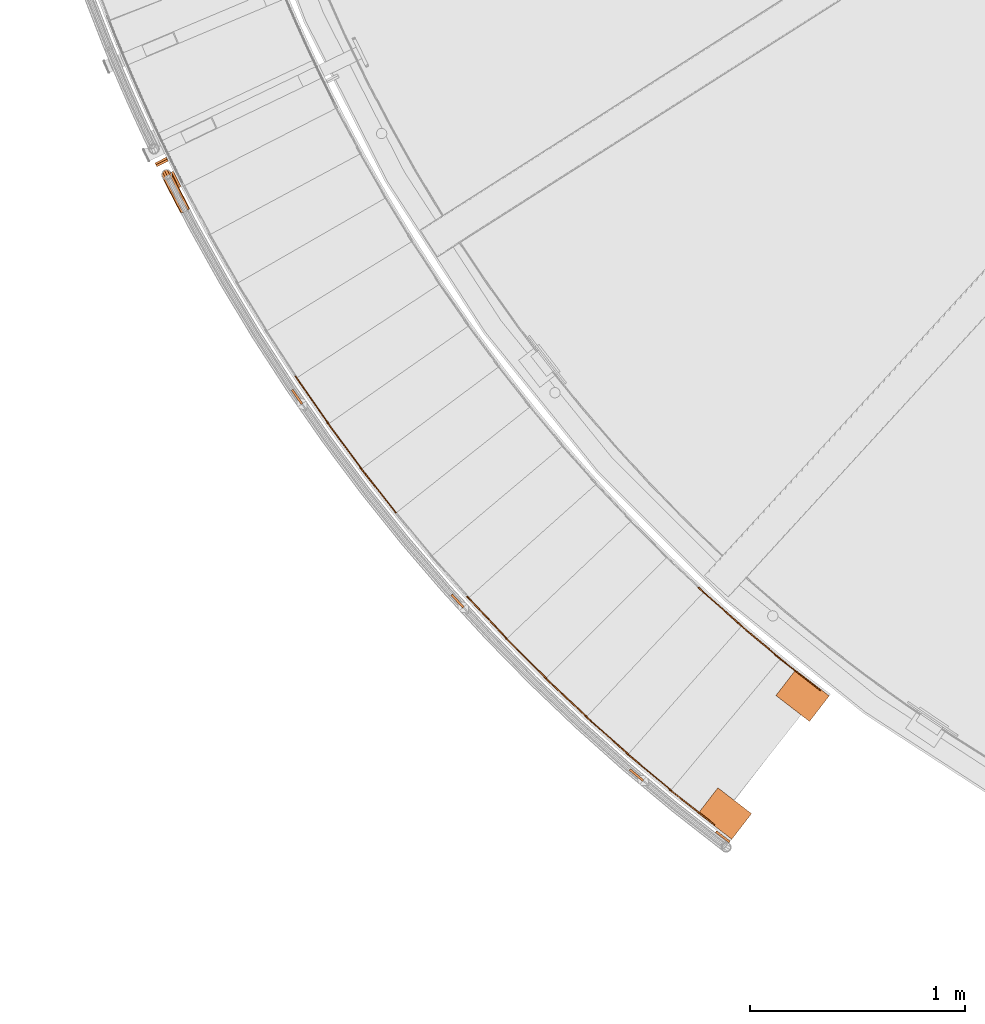
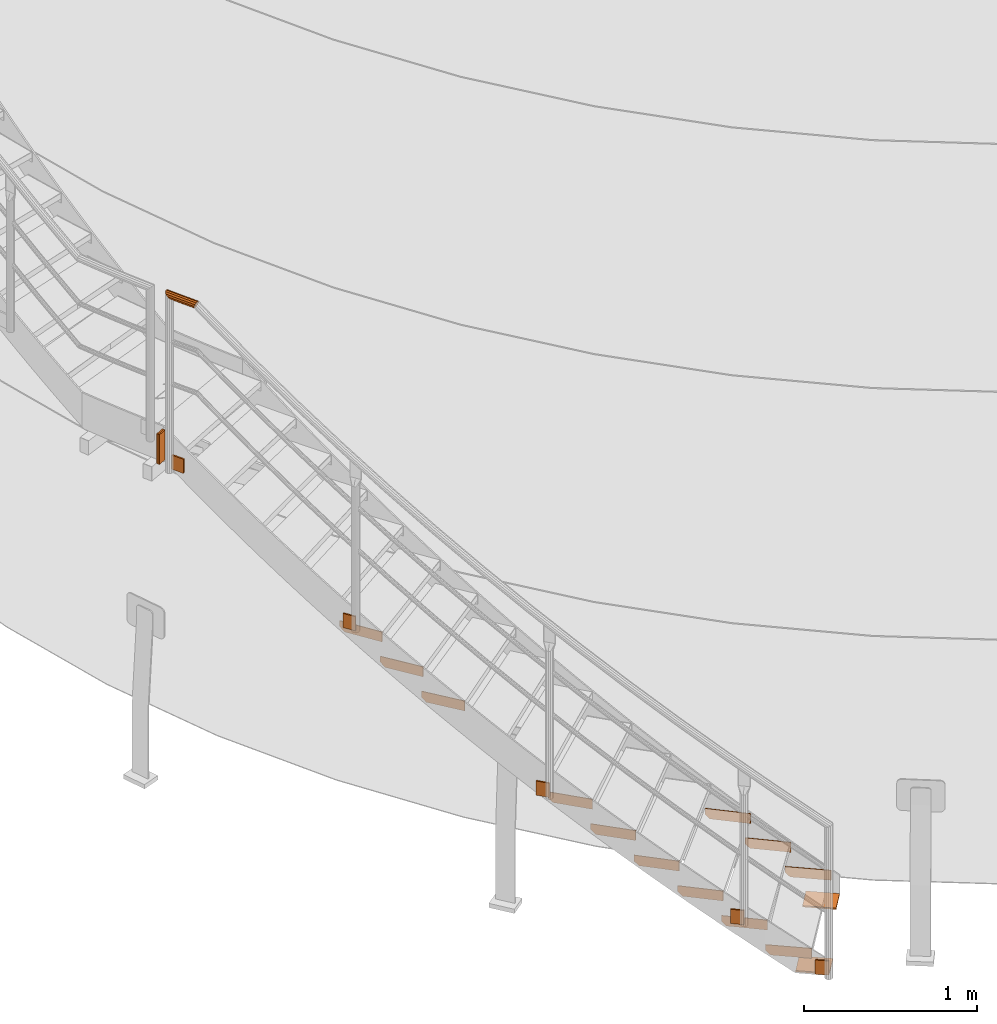
# One storey, part 44 of 126: 22 proxies.
"""IFC2X3 building model written with IfcOpenShell, lengths in millimetres."""

from ifc_helpers import new_model, si_unit, origin, origin_with_axes, place, context, project, spatial, faceted_brep, material, element, save


model = new_model("IFC2X3")

# Units and contexts
context_of_model_1 = context(None, 3, precision=0.1, world=origin())
context_of_model_2 = context(None, 3, precision=0.1, world=origin())
ifc_project = project(units=[si_unit("LENGTHUNIT", "METRE", prefix="MILLI"), si_unit("AREAUNIT", "SQUARE_METRE", prefix="CENTI"), si_unit("VOLUMEUNIT", "CUBIC_METRE", prefix="CENTI"), si_unit("MASSUNIT", "GRAM", prefix="KILO")], contexts=[context_of_model_1, context_of_model_2])

# Site, building, storey
site_placement = place(None, origin_with_axes())
site = spatial("IfcSite", under=ifc_project, at=site_placement, CompositionType="ELEMENT")
building_placement = place(site_placement, origin_with_axes())
building = spatial("IfcBuilding", under=site, at=building_placement, CompositionType="ELEMENT")
storey_placement = place(building_placement, origin_with_axes())
storey = spatial("IfcBuildingStorey", under=building, at=storey_placement, CompositionType="ELEMENT")

# Proxies
ifc_material = material(Name="S235JRG2")
proxy_1_placement = place(storey_placement, origin_with_axes())
element("IfcBuildingElementProxy", 1, at=proxy_1_placement, inside=storey, material=ifc_material, context=context_of_model_2, shape_type="Brep", body=[
    faceted_brep([(3107.5909, 1651.4086, 103.21), (3110.6795, 1655.3406, 103.21), (3110.6795, 1655.3406, 173.21), (3107.5909, 1651.4086, 173.21), (2895.2639, 1818.1936, 173.21), (2898.3525, 1822.1256, 173.21), (2898.3525, 1822.1256, 133.21), (2895.2639, 1818.1936, 133.21), (2918.8558, 1799.662, 103.21), (2921.9444, 1803.5939, 103.21)], [[[0, 1, 2, 3]], [[4, 5, 6, 7]], [[0, 8, 9, 1]], [[1, 9, 6, 5, 2]], [[2, 5, 4, 3]], [[0, 3, 4, 7, 8]], [[6, 9, 8, 7]]]),
])
proxy_2_placement = place(storey_placement, origin_with_axes())
element("IfcBuildingElementProxy", 2, at=proxy_2_placement, inside=storey, material=ifc_material, context=context_of_model_2, shape_type="Brep", body=[
    faceted_brep([(2616.5018, 1026.2235, 103.21), (2619.5904, 1030.1555, 103.21), (2619.5904, 1030.1555, 173.21), (2616.5018, 1026.2235, 173.21), (2404.1747, 1193.0085, 173.21), (2407.2634, 1196.9405, 173.21), (2407.2634, 1196.9405, 133.21), (2404.1747, 1193.0085, 133.21), (2427.7666, 1174.4768, 103.21), (2430.8552, 1178.4088, 103.21)], [[[0, 1, 2, 3]], [[4, 5, 6, 7]], [[0, 8, 9, 1]], [[1, 9, 6, 5, 2]], [[2, 5, 4, 3]], [[0, 3, 4, 7, 8]], [[6, 9, 8, 7]]]),
])
proxy_3_placement = place(storey_placement, origin_with_axes())
element("IfcBuildingElementProxy", 3, at=proxy_3_placement, inside=storey, material=ifc_material, context=context_of_model_2, shape_type="Brep", body=[
    faceted_brep([(2922.7042, 1798.3094, 276.37), (2925.9072, 1802.1487, 276.37), (2925.9072, 1802.1487, 346.37), (2922.7042, 1798.3094, 346.37), (2715.3783, 1971.2716, 346.37), (2718.5813, 1975.111, 346.37), (2718.5813, 1975.111, 306.37), (2715.3783, 1971.2716, 306.37), (2738.4145, 1952.0536, 276.37), (2741.6175, 1955.893, 276.37)], [[[0, 1, 2, 3]], [[4, 5, 6, 7]], [[0, 8, 9, 1]], [[1, 9, 6, 5, 2]], [[2, 5, 4, 3]], [[0, 3, 4, 7, 8]], [[6, 9, 8, 7]]]),
])
proxy_4_placement = place(storey_placement, origin_with_axes())
element("IfcBuildingElementProxy", 4, at=proxy_4_placement, inside=storey, material=ifc_material, context=context_of_model_2, shape_type="Brep", body=[
    faceted_brep([(2413.4264, 1187.8496, 276.37), (2416.6294, 1191.689, 276.37), (2416.6294, 1191.689, 346.37), (2413.4264, 1187.8496, 346.37), (2206.1005, 1360.8118, 346.37), (2209.3035, 1364.6512, 346.37), (2209.3035, 1364.6512, 306.37), (2206.1005, 1360.8118, 306.37), (2229.1367, 1341.5938, 276.37), (2232.3397, 1345.4332, 276.37)], [[[0, 1, 2, 3]], [[4, 5, 6, 7]], [[0, 8, 9, 1]], [[1, 9, 6, 5, 2]], [[2, 5, 4, 3]], [[0, 3, 4, 7, 8]], [[6, 9, 8, 7]]]),
])
proxy_5_placement = place(storey_placement, origin_with_axes())
element("IfcBuildingElementProxy", 5, at=proxy_5_placement, inside=storey, material=ifc_material, context=context_of_model_2, shape_type="Brep", body=[
    faceted_brep([(2742.2214, 1950.5883, 449.53), (2745.536, 1954.3318, 449.53), (2745.536, 1954.3318, 519.53), (2742.2214, 1950.5883, 519.53), (2540.0762, 2129.578, 519.53), (2543.3908, 2133.3214, 519.53), (2543.3908, 2133.3214, 479.53), (2540.0762, 2129.578, 479.53), (2562.5368, 2109.6902, 449.53), (2565.8514, 2113.4337, 449.53)], [[[0, 1, 2, 3]], [[4, 5, 6, 7]], [[0, 8, 9, 1]], [[1, 9, 6, 5, 2]], [[2, 5, 4, 3]], [[0, 3, 4, 7, 8]], [[6, 9, 8, 7]]]),
])
proxy_6_placement = place(storey_placement, origin_with_axes())
element("IfcBuildingElementProxy", 6, at=proxy_6_placement, inside=storey, material=ifc_material, context=context_of_model_2, shape_type="Brep", body=[
    faceted_brep([(2215.1963, 1355.3829, 449.53), (2218.5109, 1359.1263, 449.53), (2218.5109, 1359.1263, 519.53), (2215.1963, 1355.3829, 519.53), (2013.0511, 1534.3725, 519.53), (2016.3657, 1538.116, 519.53), (2016.3657, 1538.116, 479.53), (2013.0511, 1534.3725, 479.53), (2035.5117, 1514.4848, 449.53), (2038.8263, 1518.2282, 449.53)], [[[0, 1, 2, 3]], [[4, 5, 6, 7]], [[0, 8, 9, 1]], [[1, 9, 6, 5, 2]], [[2, 5, 4, 3]], [[0, 3, 4, 7, 8]], [[6, 9, 8, 7]]]),
])
proxy_7_placement = place(storey_placement, origin_with_axes())
element("IfcBuildingElementProxy", 7, at=proxy_7_placement, inside=storey, material=ifc_material, context=context_of_model_2, shape_type="Brep", body=[
    faceted_brep([(2021.9832, 1528.6782, 622.69), (2025.4065, 1532.3224, 622.69), (2025.4065, 1532.3224, 692.69), (2021.9832, 1528.6782, 692.69), (1825.1938, 1713.5401, 692.69), (1828.6172, 1717.1844, 692.69), (1828.6172, 1717.1844, 652.69), (1825.1938, 1713.5401, 652.69), (1847.0593, 1692.9999, 622.69), (1850.4827, 1696.6442, 622.69)], [[[0, 1, 2, 3]], [[4, 5, 6, 7]], [[0, 8, 9, 1]], [[1, 9, 6, 5, 2]], [[2, 5, 4, 3]], [[0, 3, 4, 7, 8]], [[6, 9, 8, 7]]]),
])
proxy_8_placement = place(storey_placement, origin_with_axes())
element("IfcBuildingElementProxy", 8, at=proxy_8_placement, inside=storey, material=ifc_material, context=context_of_model_2, shape_type="Brep", body=[
    faceted_brep([(1833.9544, 1707.5853, 795.85), (1837.4836, 1711.1273, 795.85), (1837.4836, 1711.1273, 865.85), (1833.9544, 1707.5853, 865.85), (1642.6915, 1898.1594, 865.85), (1646.2206, 1901.7013, 865.85), (1646.2206, 1901.7013, 825.85), (1642.6915, 1898.1594, 825.85), (1663.9429, 1876.9845, 795.85), (1667.4721, 1880.5264, 795.85)], [[[0, 1, 2, 3]], [[4, 5, 6, 7]], [[0, 8, 9, 1]], [[1, 9, 6, 5, 2]], [[2, 5, 4, 3]], [[0, 3, 4, 7, 8]], [[6, 9, 8, 7]]]),
])
proxy_9_placement = place(storey_placement, origin_with_axes())
element("IfcBuildingElementProxy", 9, at=proxy_9_placement, inside=storey, material=ifc_material, context=context_of_model_2, shape_type="Brep", body=[
    faceted_brep([(1651.273, 1891.9493, 969.01), (1654.9049, 1895.3858, 969.01), (1654.9049, 1895.3858, 1039.01), (1651.273, 1891.9493, 1039.01), (1465.7022, 2088.0704, 1039.01), (1469.3341, 2091.5069, 1039.01), (1469.3341, 2091.5069, 999.01), (1465.7022, 2088.0704, 999.01), (1486.3212, 2066.2792, 969.01), (1489.953, 2069.7157, 969.01)], [[[0, 1, 2, 3]], [[4, 5, 6, 7]], [[0, 8, 9, 1]], [[1, 9, 6, 5, 2]], [[2, 5, 4, 3]], [[0, 3, 4, 7, 8]], [[6, 9, 8, 7]]]),
])
proxy_10_placement = place(storey_placement, origin_with_axes())
element("IfcBuildingElementProxy", 10, at=proxy_10_placement, inside=storey, material=ifc_material, context=context_of_model_2, shape_type="Brep", body=[
    faceted_brep([(1136.8718, 2476.162, 1488.49), (1140.7926, 2479.2648, 1488.49), (1140.7926, 2479.2648, 1558.49), (1136.8718, 2476.162, 1558.49), (969.3217, 2687.8858, 1558.49), (973.2425, 2690.9886, 1558.49), (973.2425, 2690.9886, 1518.49), (969.3217, 2687.8858, 1518.49), (987.9384, 2664.361, 1488.49), (991.8592, 2667.4637, 1488.49)], [[[0, 1, 2, 3]], [[4, 5, 6, 7]], [[0, 8, 9, 1]], [[1, 9, 6, 5, 2]], [[2, 5, 4, 3]], [[0, 3, 4, 7, 8]], [[6, 9, 8, 7]]]),
])
proxy_11_placement = place(storey_placement, origin_with_axes())
element("IfcBuildingElementProxy", 11, at=proxy_11_placement, inside=storey, material=ifc_material, context=context_of_model_2, shape_type="Brep", body=[
    faceted_brep([(977.1143, 2680.7106, 1661.65), (981.1248, 2683.6966, 1661.65), (981.1248, 2683.6966, 1731.65), (977.1143, 2680.7106, 1731.65), (815.8686, 2897.2743, 1731.65), (819.8791, 2900.2603, 1731.65), (819.8791, 2900.2603, 1691.65), (815.8686, 2897.2743, 1691.65), (833.7848, 2873.2117, 1661.65), (837.7953, 2876.1977, 1661.65)], [[[0, 1, 2, 3]], [[4, 5, 6, 7]], [[0, 8, 9, 1]], [[1, 9, 6, 5, 2]], [[2, 5, 4, 3]], [[0, 3, 4, 7, 8]], [[6, 9, 8, 7]]]),
])
proxy_12_placement = place(storey_placement, origin_with_axes())
element("IfcBuildingElementProxy", 12, at=proxy_12_placement, inside=storey, material=ifc_material, context=context_of_model_2, shape_type="Brep", body=[
    faceted_brep([(823.4466, 2889.8728, 1834.81), (827.5432, 2892.7395, 1834.81), (827.5432, 2892.7395, 1904.81), (823.4466, 2889.8728, 1904.81), (668.645, 3111.0887, 1904.81), (672.7416, 3113.9554, 1904.81), (672.7416, 3113.9554, 1864.81), (668.645, 3111.0887, 1864.81), (685.8452, 3086.5091, 1834.81), (689.9418, 3089.3758, 1834.81)], [[[0, 1, 2, 3]], [[4, 5, 6, 7]], [[0, 8, 9, 1]], [[1, 9, 6, 5, 2]], [[2, 5, 4, 3]], [[0, 3, 4, 7, 8]], [[6, 9, 8, 7]]]),
])
proxy_13_placement = place(storey_placement, origin_with_axes())
element("IfcBuildingElementProxy", 13, at=proxy_13_placement, inside=storey, material=ifc_material, context=context_of_model_2, shape_type="Brep", body=[
    faceted_brep([(18.4377, 4102.438, 2641.25), (22.9854, 4093.5319, 2641.25), (22.9854, 4093.5319, 2851.25), (18.4377, 4102.438, 2851.25), (76.422, 4120.818, 2641.25), (71.8743, 4129.7241, 2641.25), (71.8743, 4129.7241, 2851.25), (76.422, 4120.818, 2851.25)], [[[0, 1, 2, 3]], [[4, 5, 6, 7]], [[1, 4, 7, 2]], [[0, 3, 6, 5]], [[0, 5, 4, 1]], [[2, 7, 6, 3]]]),
])
proxy_14_placement = place(storey_placement, origin_with_axes())
element("IfcBuildingElementProxy", 14, at=proxy_14_placement, inside=storey, material=ifc_material, context=context_of_model_2, shape_type="Brep", body=[
    faceted_brep([(22.9854, 4093.5319, 2641.25), (27.533, 4084.6258, 2641.25), (27.533, 4084.6258, 2851.25), (22.9854, 4093.5319, 2851.25), (80.9696, 4111.9119, 2641.25), (76.422, 4120.818, 2641.25), (76.422, 4120.818, 2851.25), (80.9696, 4111.9119, 2851.25)], [[[0, 1, 2, 3]], [[4, 5, 6, 7]], [[1, 4, 7, 2]], [[0, 3, 6, 5]], [[0, 5, 4, 1]], [[2, 7, 6, 3]]]),
])
proxy_15_placement = place(storey_placement, origin_with_axes())
element("IfcBuildingElementProxy", 15, at=proxy_15_placement, inside=storey, material=ifc_material, Name="HANDLAUF", context=context_of_model_2, shape_type="Brep", body=[
    faceted_brep([(2697.6981, 961.7717, 10.0), (2697.6981, 961.7717, 0.0), (2789.3293, 1080.5308, 0.0), (2789.3293, 1080.5308, 10.0), (2541.6434, 1082.179, 10.0), (2633.2746, 1200.9382, 10.0), (2633.2746, 1200.9382, 0.0), (2541.6434, 1082.179, 0.0)], [[[0, 1, 2, 3]], [[4, 5, 6, 7]], [[0, 4, 7, 1]], [[1, 7, 6, 2]], [[2, 6, 5, 3]], [[3, 5, 4, 0]]]),
])
proxy_16_placement = place(storey_placement, origin_with_axes())
element("IfcBuildingElementProxy", 16, at=proxy_16_placement, inside=storey, material=ifc_material, Name="HANDLAUF", context=context_of_model_2, shape_type="Brep", body=[
    faceted_brep([(3058.5583, 1508.997, 10.0), (3058.5583, 1508.997, 0.0), (3150.1894, 1627.7561, 0.0), (3150.1894, 1627.7561, 10.0), (2902.5036, 1629.4043, 10.0), (2994.1347, 1748.1635, 10.0), (2994.1347, 1748.1635, 0.0), (2902.5036, 1629.4043, 0.0)], [[[0, 1, 2, 3]], [[4, 5, 6, 7]], [[0, 4, 7, 1]], [[1, 7, 6, 2]], [[2, 6, 5, 3]], [[3, 5, 4, 0]]]),
])
proxy_17_placement = place(storey_placement, origin_with_axes())
element("IfcBuildingElementProxy", 17, at=proxy_17_placement, inside=storey, material=ifc_material, context=context_of_model_2, shape_type="Brep", body=[
    faceted_brep([(94.7892, 4059.6742, 2600.05), (103.6737, 4064.2639, 2600.05), (140.3919, 3993.1881, 2600.05), (131.5074, 3988.5983, 2600.05), (94.7892, 4059.6742, 2700.05), (131.5074, 3988.5983, 2700.05), (140.3919, 3993.1881, 2700.05), (103.6737, 4064.2639, 2700.05)], [[[0, 1, 2, 3]], [[4, 5, 6, 7]], [[0, 4, 7, 1]], [[1, 7, 6, 2]], [[0, 3, 5, 4]], [[2, 6, 5, 3]]]),
])
proxy_18_placement = place(storey_placement, origin_with_axes())
element("IfcBuildingElementProxy", 18, at=proxy_18_placement, inside=storey, material=ifc_material, Name="HANDLAUF", context=context_of_model_2, shape_type="Brep", body=[
    faceted_brep([(2690.9452, 953.0901, 9.95), (2684.8873, 945.1338, 9.95), (2621.2376, 993.5974, 9.95), (2627.2955, 1001.5536, 9.95), (2690.9452, 953.0901, 109.95), (2627.2955, 1001.5536, 109.95), (2621.2376, 993.5974, 109.95), (2684.8873, 945.1338, 109.95)], [[[0, 1, 2, 3]], [[4, 5, 6, 7]], [[0, 4, 7, 1]], [[1, 7, 6, 2]], [[2, 6, 5, 3]], [[3, 5, 4, 0]]]),
])
proxy_19_placement = place(storey_placement, origin_with_axes())
element("IfcBuildingElementProxy", 19, at=proxy_19_placement, inside=storey, material=ifc_material, Name="HANDLAUF", context=context_of_model_2, shape_type="Brep", body=[
    faceted_brep([(651.7586, 3046.3024, 1902.1208), (659.9563, 3052.0294, 1902.1208), (705.7725, 2986.4484, 1902.1208), (697.5748, 2980.7214, 1902.1208), (651.7586, 3046.3024, 2002.1208), (697.5748, 2980.7214, 2002.1208), (705.7725, 2986.4484, 2002.1208), (659.9563, 3052.0294, 2002.1208)], [[[0, 1, 2, 3]], [[4, 5, 6, 7]], [[0, 4, 7, 1]], [[1, 7, 6, 2]], [[2, 6, 5, 3]], [[3, 5, 4, 0]]]),
])
proxy_20_placement = place(storey_placement, origin_with_axes())
element("IfcBuildingElementProxy", 20, at=proxy_20_placement, inside=storey, material=ifc_material, Name="HANDLAUF", context=context_of_model_2, shape_type="Brep", body=[
    faceted_brep([(2220.9411, 1281.8544, 333.8049), (2227.3456, 1289.5344, 333.8049), (2288.7854, 1238.2982, 333.8049), (2282.3809, 1230.6183, 333.8049), (2220.9411, 1281.8544, 433.8049), (2282.3809, 1230.6183, 433.8049), (2288.7854, 1238.2982, 433.8049), (2227.3456, 1289.5344, 433.8049)], [[[0, 1, 2, 3]], [[4, 5, 6, 7]], [[0, 4, 7, 1]], [[1, 7, 6, 2]], [[2, 6, 5, 3]], [[3, 5, 4, 0]]]),
])
proxy_21_placement = place(storey_placement, origin_with_axes())
element("IfcBuildingElementProxy", 21, at=proxy_21_placement, inside=storey, material=ifc_material, Name="HANDLAUF", context=context_of_model_2, shape_type="Brep", body=[
    faceted_brep([(1393.0645, 2094.5265, 1036.3508), (1400.4305, 2101.2897, 1036.3508), (1454.5361, 2042.361, 1036.3508), (1447.17, 2035.5978, 1036.3508), (1393.0645, 2094.5265, 1136.3508), (1447.17, 2035.5978, 1136.3508), (1454.5361, 2042.361, 1136.3508), (1400.4305, 2101.2897, 1136.3508)], [[[0, 1, 2, 3]], [[4, 5, 6, 7]], [[0, 4, 7, 1]], [[1, 7, 6, 2]], [[2, 6, 5, 3]], [[3, 5, 4, 0]]]),
])
proxy_22_placement = place(storey_placement, origin_with_axes())
element("IfcBuildingElementProxy", 22, at=proxy_22_placement, inside=storey, material=ifc_material, Name="HANDLAUF", context=context_of_model_2, shape_type="Brep", body=[
    faceted_brep([(77.008, 4067.7028, 3868.0145), (81.536, 4069.9607, 3862.9548), (74.7065, 4072.3386, 3868.0145), (62.3395, 4070.0944, 3871.25), (66.2018, 4062.3145, 3871.25), (52.8505, 4062.0529, 3868.0145), (55.3957, 4056.9262, 3868.0145), (50.1557, 4054.3134, 3862.1592), (56.5144, 4057.484, 3865.8494), (53.2829, 4055.8727, 3862.2385), (54.9448, 4060.6456, 3865.8494), (63.4514, 4067.8547, 3868.75), (66.2018, 4062.3145, 3868.75), (74.5382, 4069.8666, 3865.8494), (75.8893, 4067.145, 3865.8494), (78.5476, 4068.4705, 3862.879), (58.4827, 4023.7969, 3847.1), (51.2718, 4038.1951, 3847.1), (59.609, 4028.7734, 3835.025), (61.3731, 4025.2508, 3835.025), (64.8018, 4026.9754, 3831.187), (98.7413, 4044.0469, 3835.025), (96.1327, 4042.7348, 3832.1051), (97.4676, 4046.5902, 3835.025), (94.9872, 4058.7682, 3847.1), (101.6317, 4045.5008, 3847.1), (86.6501, 4068.19, 3859.175), (98.7413, 4044.0469, 3859.175), (90.8444, 4040.0748, 3868.0145), (80.0572, 4034.6489, 3871.25), (69.2699, 4029.2229, 3868.0145), (48.7915, 4050.3732, 3859.175), (61.3731, 4025.2508, 3859.175), (60.7161, 4024.9203, 3847.1), (53.5345, 4039.26, 3847.1), (51.3109, 4050.1774, 3857.925), (63.3073, 4026.2237, 3857.925), (70.3866, 4029.7846, 3865.8494), (80.0572, 4034.6489, 3868.75), (89.7277, 4039.5131, 3865.8494), (85.2504, 4066.1498, 3857.925), (96.8071, 4043.074, 3857.925), (92.7245, 4057.7033, 3847.1), (99.3983, 4044.3774, 3847.1), (94.9481, 4046.786, 3836.275), (96.8071, 4043.074, 3836.275), (92.9999, 4041.159, 3832.0133), (63.3073, 4026.2237, 3836.275), (67.7748, 4028.4709, 3831.2741), (61.0086, 4030.8136, 3836.275), (75.3579, 3997.5685, 3835.025), (72.4725, 3996.1045, 3847.1), (71.5851, 4024.64, 3826.1855), (83.2408, 4001.5681, 3826.1855), (83.9745, 4026.8948, 3822.95), (94.009, 4007.0317, 3822.95), (93.4448, 4034.9275, 3826.1855), (104.7773, 4012.4953, 3826.1855), (112.6602, 4016.495, 3835.025), (115.5455, 4017.9589, 3847.1), (112.6602, 4016.495, 3859.175), (104.7773, 4012.4953, 3868.0145), (94.009, 4007.0317, 3871.25), (83.2408, 4001.5681, 3868.0145), (75.3579, 3997.5685, 3859.175), (77.2886, 3998.5481, 3857.925), (74.702, 3997.2357, 3847.1), (84.3555, 4002.1337, 3865.8494), (94.009, 4007.0317, 3868.75), (103.6625, 4011.9297, 3865.8494), (110.7294, 4015.5153, 3857.925), (113.3161, 4016.8277, 3847.1), (110.7294, 4015.5153, 3836.275), (91.3367, 4036.3283, 3828.3506), (103.6625, 4011.9297, 3828.3506), (82.8467, 4029.127, 3825.45), (94.009, 4007.0317, 3825.45), (71.7399, 4027.1057, 3828.3506), (84.3555, 4002.1337, 3828.3506), (77.2886, 3998.5481, 3836.275), (89.4392, 3969.9352, 3835.025), (86.5589, 3968.4612, 3847.1), (97.3081, 3973.9623, 3826.1855), (108.0572, 3979.4635, 3822.95), (118.8063, 3984.9646, 3826.1855), (126.6752, 3988.9917, 3835.025), (129.5554, 3990.4658, 3847.1), (126.6752, 3988.9917, 3859.175), (118.8063, 3984.9646, 3868.0145), (108.0572, 3979.4635, 3871.25), (97.3081, 3973.9623, 3868.0145), (89.4392, 3969.9352, 3859.175), (91.3665, 3970.9216, 3857.925), (88.7844, 3969.6001, 3847.1), (98.4208, 3974.5318, 3865.8494), (108.0572, 3979.4635, 3868.75), (117.6935, 3984.3951, 3865.8494), (124.7478, 3988.0054, 3857.925), (127.3299, 3989.3268, 3847.1), (124.7478, 3988.0054, 3836.275), (117.6935, 3984.3951, 3828.3506), (108.0572, 3979.4635, 3825.45), (98.4208, 3974.5318, 3828.3506), (91.3665, 3970.9216, 3836.275), (103.6168, 3942.3512, 3835.025), (100.7418, 3940.8671, 3847.1), (111.4716, 3946.4058, 3826.1855), (122.2015, 3951.9444, 3822.95), (132.9313, 3957.483, 3826.1855), (140.7861, 3961.5376, 3835.025), (143.6612, 3963.0217, 3847.1), (140.7861, 3961.5376, 3859.175), (132.9313, 3957.483, 3868.0145), (122.2015, 3951.9444, 3871.25), (111.4716, 3946.4058, 3868.0145), (103.6168, 3942.3512, 3859.175), (105.5407, 3943.3443, 3857.925), (102.9633, 3942.0138, 3847.1), (112.5824, 3946.9791, 3865.8494), (122.2015, 3951.9444, 3868.75), (131.8206, 3956.9097, 3865.8494), (138.8622, 3960.5445, 3857.925), (141.4397, 3961.875, 3847.1), (138.8622, 3960.5445, 3836.275), (131.8206, 3956.9097, 3828.3506), (122.2015, 3951.9444, 3825.45), (112.5824, 3946.9791, 3828.3506), (105.5407, 3943.3443, 3836.275), (117.8907, 3914.8169, 3835.025), (115.0208, 3913.3228, 3847.1), (125.7313, 3918.8988, 3826.1855), (136.4417, 3924.4749, 3822.95), (147.1522, 3930.051, 3826.1855), (154.9928, 3934.1329, 3835.025), (157.8626, 3935.627, 3847.1), (154.9928, 3934.1329, 3859.175), (147.1522, 3930.051, 3868.0145), (136.4417, 3924.4749, 3871.25), (125.7313, 3918.8988, 3868.0145), (117.8907, 3914.8169, 3859.175), (119.8111, 3915.8167, 3857.925), (117.2383, 3914.4772, 3847.1), (126.84, 3919.4761, 3865.8494), (136.4417, 3924.4749, 3868.75), (146.0434, 3929.4737, 3865.8494), (153.0724, 3933.1331, 3857.925), (155.6451, 3934.4725, 3847.1), (153.0724, 3933.1331, 3836.275), (146.0434, 3929.4737, 3828.3506), (136.4417, 3924.4749, 3825.45), (126.84, 3919.4761, 3828.3506), (119.8111, 3915.8167, 3836.275), (132.2606, 3887.3325, 3835.025), (129.396, 3885.8284, 3847.1), (140.0869, 3891.4418, 3826.1855), (150.7778, 3897.0553, 3822.95), (161.4687, 3902.6687, 3826.1855), (169.295, 3906.778, 3835.025), (172.1596, 3908.2821, 3847.1), (169.295, 3906.778, 3859.175), (161.4687, 3902.6687, 3868.0145), (150.7778, 3897.0553, 3871.25), (140.0869, 3891.4418, 3868.0145), (132.2606, 3887.3325, 3859.175), (134.1775, 3888.339, 3857.925), (131.6094, 3886.9906, 3847.1), (141.1936, 3892.0229, 3865.8494), (150.7778, 3897.0553, 3868.75), (160.362, 3902.0876, 3865.8494), (167.3781, 3905.7715, 3857.925), (169.9462, 3907.1199, 3847.1), (167.3781, 3905.7715, 3836.275), (160.362, 3902.0876, 3828.3506), (150.7778, 3897.0553, 3825.45), (141.1936, 3892.0229, 3828.3506), (134.1775, 3888.339, 3836.275), (137.0657, 3878.2197, 3835.025), (135.9422, 3873.4136, 3847.1), (143.7005, 3884.5887, 3826.1855), (154.0687, 3890.8141, 3822.95), (165.3923, 3895.2277, 3826.1855), (174.637, 3896.647, 3835.025), (179.3258, 3894.6916, 3847.1), (178.2023, 3889.8855, 3859.175), (171.5675, 3883.5165, 3868.0145), (161.1993, 3877.2911, 3871.25), (149.8757, 3872.8775, 3868.0145), (140.631, 3871.4582, 3859.175), (142.3911, 3872.762, 3857.925), (138.1877, 3874.515, 3847.1), (150.6789, 3874.0343, 3865.8494), (160.8302, 3877.9911, 3868.75), (170.1251, 3883.572, 3865.8494), (176.0731, 3889.2817, 3857.925), (177.0803, 3893.5902, 3847.1), (172.8769, 3895.3432, 3836.275), (164.5891, 3894.0709, 3828.3506), (154.4378, 3890.1141, 3825.45), (145.1429, 3884.5332, 3828.3506), (139.1949, 3878.8235, 3836.275)], [[[0, 1, 2]], [[0, 2, 3, 4]], [[4, 3, 5, 6]], [[6, 5, 7]], [[8, 9, 10]], [[8, 10, 11, 12]], [[12, 11, 13, 14]], [[14, 13, 15]], [[16, 17, 18, 19]], [[19, 18, 20]], [[21, 22, 23]], [[21, 23, 24, 25]], [[25, 24, 26, 27]], [[0, 28, 27, 26, 1]], [[0, 4, 29, 28]], [[4, 6, 30, 29]], [[31, 32, 30, 6, 7]], [[16, 32, 31, 17]], [[33, 34, 35, 36]], [[35, 9, 8, 37, 36]], [[8, 12, 38, 37]], [[12, 14, 39, 38]], [[14, 15, 40, 41, 39]], [[41, 40, 42, 43]], [[43, 42, 44, 45]], [[45, 44, 46]], [[47, 48, 49]], [[33, 47, 49, 34]], [[16, 19, 50, 51]], [[19, 20, 52, 53, 50]], [[53, 52, 54, 55]], [[55, 54, 56, 57]], [[56, 22, 21, 58, 57]], [[21, 25, 59, 58]], [[25, 27, 60, 59]], [[27, 28, 61, 60]], [[28, 29, 62, 61]], [[29, 30, 63, 62]], [[30, 32, 64, 63]], [[32, 16, 51, 64]], [[33, 36, 65, 66]], [[36, 37, 67, 65]], [[37, 38, 68, 67]], [[38, 39, 69, 68]], [[39, 41, 70, 69]], [[41, 43, 71, 70]], [[43, 45, 72, 71]], [[73, 74, 72, 45, 46]], [[74, 73, 75, 76]], [[76, 75, 77, 78]], [[47, 79, 78, 77, 48]], [[47, 33, 66, 79]], [[51, 50, 80, 81]], [[50, 53, 82, 80]], [[53, 55, 83, 82]], [[55, 57, 84, 83]], [[57, 58, 85, 84]], [[58, 59, 86, 85]], [[59, 60, 87, 86]], [[60, 61, 88, 87]], [[61, 62, 89, 88]], [[62, 63, 90, 89]], [[63, 64, 91, 90]], [[64, 51, 81, 91]], [[66, 65, 92, 93]], [[65, 67, 94, 92]], [[67, 68, 95, 94]], [[68, 69, 96, 95]], [[69, 70, 97, 96]], [[70, 71, 98, 97]], [[71, 72, 99, 98]], [[72, 74, 100, 99]], [[74, 76, 101, 100]], [[76, 78, 102, 101]], [[78, 79, 103, 102]], [[79, 66, 93, 103]], [[81, 80, 104, 105]], [[80, 82, 106, 104]], [[82, 83, 107, 106]], [[83, 84, 108, 107]], [[84, 85, 109, 108]], [[85, 86, 110, 109]], [[86, 87, 111, 110]], [[87, 88, 112, 111]], [[88, 89, 113, 112]], [[89, 90, 114, 113]], [[90, 91, 115, 114]], [[91, 81, 105, 115]], [[93, 92, 116, 117]], [[92, 94, 118, 116]], [[94, 95, 119, 118]], [[95, 96, 120, 119]], [[96, 97, 121, 120]], [[97, 98, 122, 121]], [[98, 99, 123, 122]], [[99, 100, 124, 123]], [[100, 101, 125, 124]], [[101, 102, 126, 125]], [[102, 103, 127, 126]], [[103, 93, 117, 127]], [[105, 104, 128, 129]], [[104, 106, 130, 128]], [[106, 107, 131, 130]], [[107, 108, 132, 131]], [[108, 109, 133, 132]], [[109, 110, 134, 133]], [[110, 111, 135, 134]], [[111, 112, 136, 135]], [[112, 113, 137, 136]], [[113, 114, 138, 137]], [[114, 115, 139, 138]], [[115, 105, 129, 139]], [[117, 116, 140, 141]], [[116, 118, 142, 140]], [[118, 119, 143, 142]], [[119, 120, 144, 143]], [[120, 121, 145, 144]], [[121, 122, 146, 145]], [[122, 123, 147, 146]], [[123, 124, 148, 147]], [[124, 125, 149, 148]], [[125, 126, 150, 149]], [[126, 127, 151, 150]], [[127, 117, 141, 151]], [[129, 128, 152, 153]], [[128, 130, 154, 152]], [[130, 131, 155, 154]], [[131, 132, 156, 155]], [[132, 133, 157, 156]], [[133, 134, 158, 157]], [[134, 135, 159, 158]], [[135, 136, 160, 159]], [[136, 137, 161, 160]], [[137, 138, 162, 161]], [[138, 139, 163, 162]], [[139, 129, 153, 163]], [[141, 140, 164, 165]], [[140, 142, 166, 164]], [[142, 143, 167, 166]], [[143, 144, 168, 167]], [[144, 145, 169, 168]], [[145, 146, 170, 169]], [[146, 147, 171, 170]], [[147, 148, 172, 171]], [[148, 149, 173, 172]], [[149, 150, 174, 173]], [[150, 151, 175, 174]], [[151, 141, 165, 175]], [[152, 176, 177, 153]], [[152, 154, 178, 176]], [[154, 155, 179, 178]], [[155, 156, 180, 179]], [[156, 157, 181, 180]], [[157, 158, 182, 181]], [[158, 159, 183, 182]], [[159, 160, 184, 183]], [[160, 161, 185, 184]], [[161, 162, 186, 185]], [[162, 163, 187, 186]], [[153, 177, 187, 163]], [[164, 188, 189, 165]], [[164, 166, 190, 188]], [[166, 167, 191, 190]], [[167, 168, 192, 191]], [[168, 169, 193, 192]], [[169, 170, 194, 193]], [[170, 171, 195, 194]], [[171, 172, 196, 195]], [[172, 173, 197, 196]], [[173, 174, 198, 197]], [[174, 175, 199, 198]], [[165, 189, 199, 175]], [[17, 31, 7, 5, 3, 2, 1, 26, 24, 23, 22, 56, 54, 52, 20, 18], [10, 9, 35, 34, 49, 48, 77, 75, 73, 46, 44, 42, 40, 15, 13, 11]], [[185, 186, 187, 177, 176, 178, 179, 180, 181, 182, 183, 184], [188, 190, 191, 192, 193, 194, 195, 196, 197, 198, 199, 189]]]),
])

save(model, "model.ifc")
